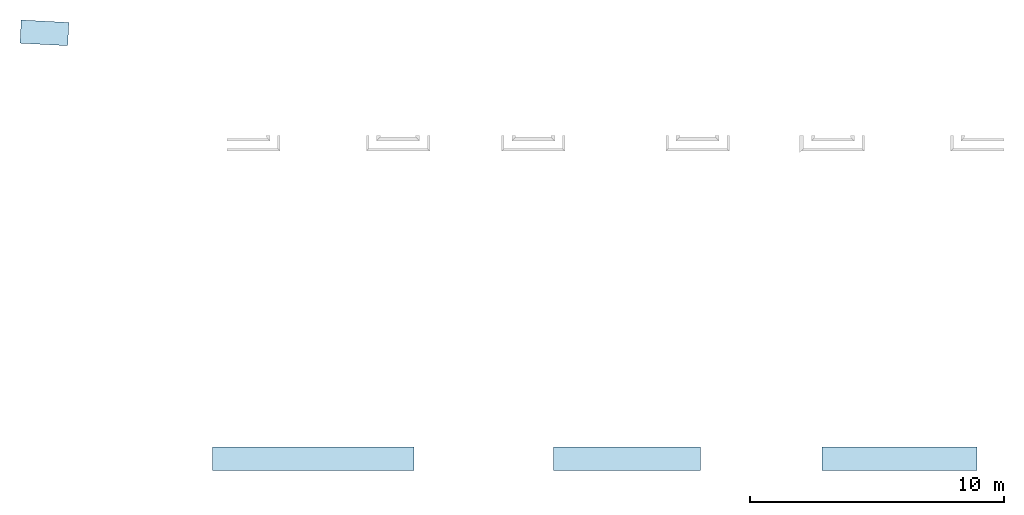
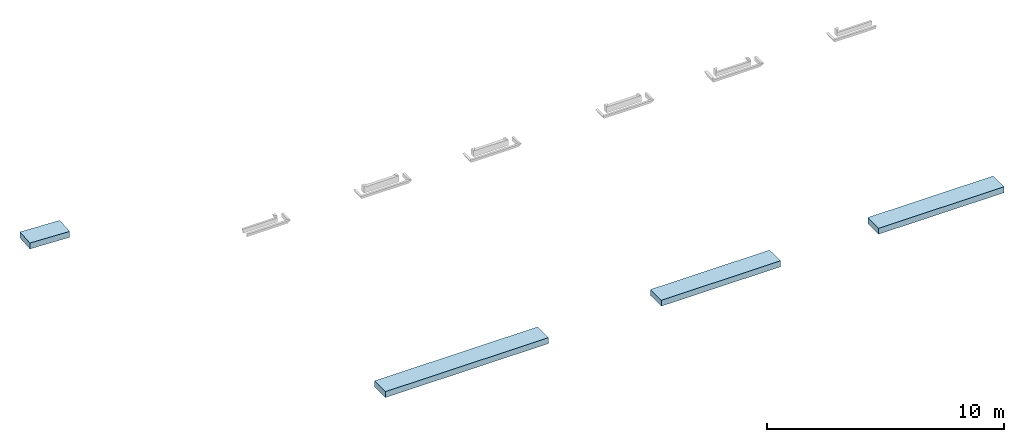
# One storey, part 1 of 8: 4 footings.
"""IFC4 building model written with IfcOpenShell, lengths in feet."""

from ifc_helpers import new_model, entity, si_unit, converted_unit, derived_unit, direction, frame, frame_2d, origin, origin_2d_with_axis, place, context, subcontext, project, spatial, rectangle, extrude, material, type_object, element, save


model = new_model("IFC4")

# Units and contexts
model_context = context("Model", 3, precision=0.0001, world=origin(), true_north=direction((6.12303176911189e-17, 1.0)))
body_context = subcontext(model_context, "Body", "Model", "MODEL_VIEW")
ifc_project = project(units=[converted_unit("LENGTHUNIT", "FOOT", entity("IfcRatioMeasure", 0.3048), si_unit("LENGTHUNIT", "METRE"), dimensions=[1, 0, 0, 0, 0, 0, 0]), converted_unit("AREAUNIT", "SQUARE FOOT", entity("IfcRatioMeasure", 0.09290304), si_unit("AREAUNIT", "SQUARE_METRE"), dimensions=[2, 0, 0, 0, 0, 0, 0]), converted_unit("VOLUMEUNIT", "CUBIC FOOT", entity("IfcRatioMeasure", 0.028316846592), si_unit("VOLUMEUNIT", "CUBIC_METRE"), dimensions=[3, 0, 0, 0, 0, 0, 0]), converted_unit("PLANEANGLEUNIT", "DEGREE", entity("IfcRatioMeasure", 0.0174532925199433), si_unit("PLANEANGLEUNIT", "RADIAN"), dimensions=[0, 0, 0, 0, 0, 0, 0]), si_unit("MASSUNIT", "GRAM", prefix="KILO"), derived_unit("MASSDENSITYUNIT", [(si_unit("MASSUNIT", "GRAM", prefix="KILO"), 1), (si_unit("LENGTHUNIT", "METRE"), -3)]), derived_unit("MOMENTOFINERTIAUNIT", [(si_unit("LENGTHUNIT", "METRE"), 4)]), si_unit("TIMEUNIT", "SECOND"), si_unit("FREQUENCYUNIT", "HERTZ"), si_unit("THERMODYNAMICTEMPERATUREUNIT", "DEGREE_CELSIUS"), derived_unit("THERMALTRANSMITTANCEUNIT", [(si_unit("MASSUNIT", "GRAM", prefix="KILO"), 1), (si_unit("THERMODYNAMICTEMPERATUREUNIT", "KELVIN"), -1), (si_unit("TIMEUNIT", "SECOND"), -3)]), derived_unit("VOLUMETRICFLOWRATEUNIT", [(si_unit("LENGTHUNIT", "METRE"), 3), (si_unit("TIMEUNIT", "SECOND"), -1)]), si_unit("ELECTRICCURRENTUNIT", "AMPERE"), si_unit("ELECTRICVOLTAGEUNIT", "VOLT"), si_unit("POWERUNIT", "WATT"), si_unit("FORCEUNIT", "NEWTON"), si_unit("ILLUMINANCEUNIT", "LUX"), si_unit("LUMINOUSFLUXUNIT", "LUMEN"), si_unit("LUMINOUSINTENSITYUNIT", "CANDELA"), derived_unit("USERDEFINED", [(si_unit("MASSUNIT", "GRAM", prefix="KILO"), -1), (si_unit("LENGTHUNIT", "METRE"), -2), (si_unit("TIMEUNIT", "SECOND"), 3), (si_unit("LUMINOUSFLUXUNIT", "LUMEN"), 1)]), derived_unit("LINEARVELOCITYUNIT", [(si_unit("LENGTHUNIT", "METRE"), 1), (si_unit("TIMEUNIT", "SECOND"), -1)]), si_unit("PRESSUREUNIT", "PASCAL"), derived_unit("USERDEFINED", [(si_unit("LENGTHUNIT", "METRE"), -2), (si_unit("MASSUNIT", "GRAM", prefix="KILO"), 1), (si_unit("TIMEUNIT", "SECOND"), -2)]), derived_unit("LINEARFORCEUNIT", [(si_unit("MASSUNIT", "GRAM", prefix="KILO"), 1), (si_unit("LENGTHUNIT", "METRE"), 1), (si_unit("TIMEUNIT", "SECOND"), -2), (si_unit("LENGTHUNIT", "METRE"), -1)]), derived_unit("PLANARFORCEUNIT", [(si_unit("MASSUNIT", "GRAM", prefix="KILO"), 1), (si_unit("LENGTHUNIT", "METRE"), 1), (si_unit("TIMEUNIT", "SECOND"), -2), (si_unit("LENGTHUNIT", "METRE"), -2)])], contexts=[model_context])

# Site, building, storey
site_placement = place(None, origin())
site = spatial("IfcSite", under=ifc_project, at=site_placement, CompositionType="ELEMENT")
building_placement = place(site_placement, origin())
building = spatial("IfcBuilding", under=site, at=building_placement, CompositionType="ELEMENT")
storey_placement = place(building_placement, frame((0.0, 0.0, -12.6666666666667)))
storey = spatial("IfcBuildingStorey", under=building, at=storey_placement, Name="BASEMENT", CompositionType="ELEMENT", Elevation=-12.6666666666667)

# Footings
ifc_material = material(Name="CONCRETE FOOTING - SEE SCHEDULE", Category="Materials")
footing_type_1 = type_object("IfcFootingType", Name="Wall Foundation:UNDER LANDSCAPE WALLS", PredefinedType="STRIP_FOOTING")
footing_1_placement = place(storey_placement, frame((-255.071493818862, 914.695268215984, 10.3333333333333)))
element("IfcFooting", 1, at=footing_1_placement, inside=storey, type_object=footing_type_1, material=ifc_material, Name="Wall Foundation:UNDER LANDSCAPE WALLS", ObjectType="Wall Foundation:UNDER LANDSCAPE WALLS", PredefinedType="STRIP_FOOTING", context=body_context, shape_type="SweptSolid", body=[
    extrude(rectangle(XDim=26.0, YDim=3.0, at=origin_2d_with_axis()), frame((13.0, 1.50000000000011, 0.0), z_axis=(0.0, 0.0, 1.0), x_axis=(-1.0, 0.0, 0.0)), (0.0, 0.0, 1.0), 1.0),
])
footing_type_2 = type_object("IfcFootingType", Name="Wall Foundation:UNDER LANDSCAPE WALLS", PredefinedType="STRIP_FOOTING")
footing_2_placement = place(storey_placement, frame((-211.071493818862, 914.695268215984, 10.3333333333333)))
element("IfcFooting", 2, at=footing_2_placement, inside=storey, type_object=footing_type_2, material=ifc_material, Name="Wall Foundation:UNDER LANDSCAPE WALLS", ObjectType="Wall Foundation:UNDER LANDSCAPE WALLS", PredefinedType="STRIP_FOOTING", context=body_context, shape_type="SweptSolid", body=[
    extrude(rectangle(XDim=19.0, YDim=3.0, at=origin_2d_with_axis()), frame((9.5, 1.50000000000011, 0.0), z_axis=(0.0, 0.0, 1.0), x_axis=(-1.0, 0.0, 0.0)), (0.0, 0.0, 1.0), 1.0),
])
footing_type_3 = type_object("IfcFootingType", Name="Wall Foundation:UNDER LANDSCAPE WALLS", PredefinedType="STRIP_FOOTING")
footing_3_placement = place(storey_placement, frame((-176.404827152196, 914.695268215983, 10.3333333333333)))
element("IfcFooting", 3, at=footing_3_placement, inside=storey, type_object=footing_type_3, material=ifc_material, Name="Wall Foundation:UNDER LANDSCAPE WALLS", ObjectType="Wall Foundation:UNDER LANDSCAPE WALLS", PredefinedType="STRIP_FOOTING", context=body_context, shape_type="SweptSolid", body=[
    extrude(rectangle(XDim=20.0, YDim=3.0, at=origin_2d_with_axis()), frame((10.0, 1.50000000000011, 0.0), z_axis=(0.0, 0.0, 1.0), x_axis=(-1.0, 0.0, 0.0)), (0.0, 0.0, 1.0), 1.0),
])
footing_type_4 = type_object("IfcFootingType", Name="Wall Foundation:UNDER LANDSCAPE WALLS", PredefinedType="STRIP_FOOTING")
footing_4_placement = place(storey_placement, frame((-279.956520921968, 969.513383675255, 10.6666666666666)))
element("IfcFooting", 4, at=footing_4_placement, inside=storey, type_object=footing_type_4, material=ifc_material, Name="Wall Foundation:UNDER LANDSCAPE WALLS", ObjectType="Wall Foundation:UNDER LANDSCAPE WALLS", PredefinedType="STRIP_FOOTING", context=body_context, shape_type="SweptSolid", body=[
    extrude(rectangle(XDim=6.16575176933464, YDim=3.00000000000004, at=frame_2d((-2.8421709430404e-14, -1.55431223447522e-15), x_axis=(1.0, 0.0))), frame((3.15715484477579, 1.65928955953416, 0.0), z_axis=(0.0, 0.0, 1.0), x_axis=(-0.998629534754576, 0.052335956242911, 0.0)), (0.0, 0.0, 1.0), 1.0),
])

save(model, "model.ifc")
